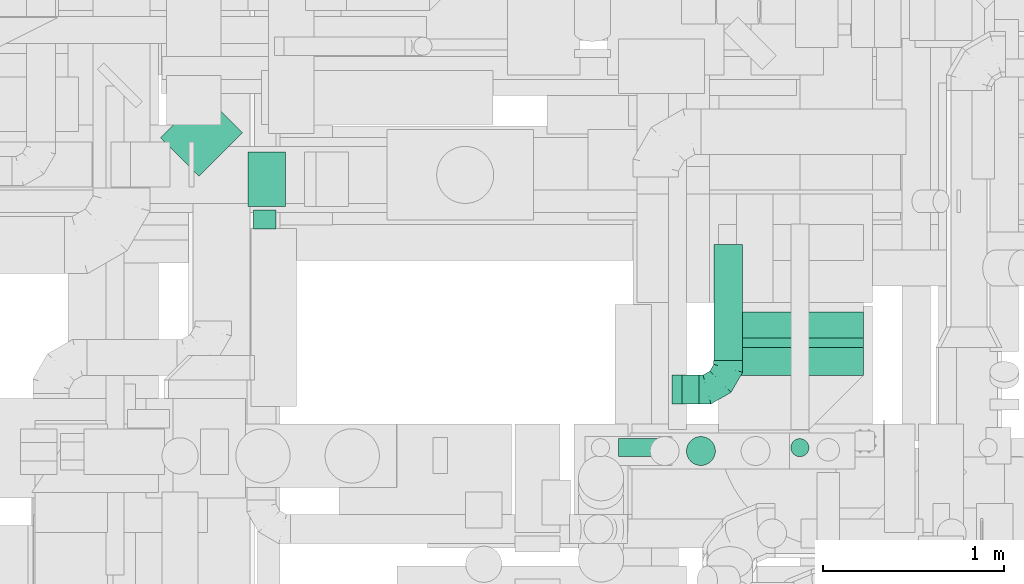
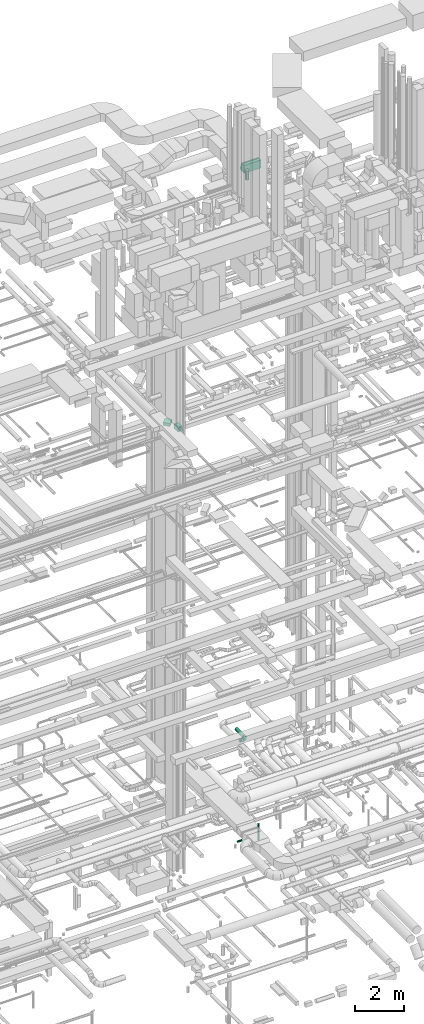
# One storey, part 190 of 337: 9 flow segments, 3 flow fittings.
"""IFC2X3 building model written with IfcOpenShell, lengths in millimetres."""

from ifc_helpers import new_model, entity, si_unit, converted_unit, derived_unit, direction, frame, frame_2d, origin, origin_2d_with_axis, place, context, subcontext, project, spatial, polyline, circle_curve, parameter, trimmed, segment, composite_curve, rectangle, circle, outline, extrude, faceted_brep, source, transform, mapped, material, type_object, type_shapes, element, save


model = new_model("IFC2X3")

# Units and contexts
model_context = context("Model", 3, precision=0.01, world=origin(), true_north=direction((6.12303176911189e-17, 1.0)))
body_context = subcontext(model_context, "Body", "Model", "MODEL_VIEW")
ifc_project = project(units=[si_unit("LENGTHUNIT", "METRE", prefix="MILLI"), si_unit("AREAUNIT", "SQUARE_METRE"), si_unit("VOLUMEUNIT", "CUBIC_METRE"), converted_unit("PLANEANGLEUNIT", "DEGREE", entity("IfcRatioMeasure", 0.0174532925199433), si_unit("PLANEANGLEUNIT", "RADIAN"), dimensions=[0, 0, 0, 0, 0, 0, 0]), si_unit("MASSUNIT", "GRAM", prefix="KILO"), derived_unit("MASSDENSITYUNIT", [(si_unit("MASSUNIT", "GRAM", prefix="KILO"), 1), (si_unit("LENGTHUNIT", "METRE"), -3)]), derived_unit("MOMENTOFINERTIAUNIT", [(si_unit("LENGTHUNIT", "METRE"), 4)]), si_unit("TIMEUNIT", "SECOND"), si_unit("FREQUENCYUNIT", "HERTZ"), si_unit("THERMODYNAMICTEMPERATUREUNIT", "DEGREE_CELSIUS"), derived_unit("THERMALTRANSMITTANCEUNIT", [(si_unit("MASSUNIT", "GRAM", prefix="KILO"), 1), (si_unit("THERMODYNAMICTEMPERATUREUNIT", "KELVIN"), -1), (si_unit("TIMEUNIT", "SECOND"), -3)]), derived_unit("VOLUMETRICFLOWRATEUNIT", [(si_unit("LENGTHUNIT", "METRE"), 3), (si_unit("TIMEUNIT", "SECOND"), -1)]), derived_unit("MASSFLOWRATEUNIT", [(si_unit("MASSUNIT", "GRAM", prefix="KILO"), 1), (si_unit("TIMEUNIT", "SECOND"), -1)]), derived_unit("ROTATIONALFREQUENCYUNIT", [(si_unit("TIMEUNIT", "SECOND"), -1)]), si_unit("ELECTRICCURRENTUNIT", "AMPERE"), si_unit("ELECTRICVOLTAGEUNIT", "VOLT"), si_unit("POWERUNIT", "WATT"), si_unit("FORCEUNIT", "NEWTON", prefix="KILO"), si_unit("ILLUMINANCEUNIT", "LUX"), si_unit("LUMINOUSFLUXUNIT", "LUMEN"), si_unit("LUMINOUSINTENSITYUNIT", "CANDELA"), derived_unit("USERDEFINED", [(si_unit("MASSUNIT", "GRAM", prefix="KILO"), -1), (si_unit("LENGTHUNIT", "METRE"), -2), (si_unit("TIMEUNIT", "SECOND"), 3), (si_unit("LUMINOUSFLUXUNIT", "LUMEN"), 1)]), derived_unit("LINEARVELOCITYUNIT", [(si_unit("LENGTHUNIT", "METRE"), 1), (si_unit("TIMEUNIT", "SECOND"), -1)]), si_unit("PRESSUREUNIT", "PASCAL"), derived_unit("USERDEFINED", [(si_unit("LENGTHUNIT", "METRE"), -2), (si_unit("MASSUNIT", "GRAM", prefix="KILO"), 1), (si_unit("TIMEUNIT", "SECOND"), -2)]), derived_unit("LINEARFORCEUNIT", [(si_unit("MASSUNIT", "GRAM", prefix="KILO"), 1), (si_unit("LENGTHUNIT", "METRE"), 1), (si_unit("TIMEUNIT", "SECOND"), -2), (si_unit("LENGTHUNIT", "METRE"), -1)]), derived_unit("PLANARFORCEUNIT", [(si_unit("MASSUNIT", "GRAM", prefix="KILO"), 1), (si_unit("LENGTHUNIT", "METRE"), 1), (si_unit("TIMEUNIT", "SECOND"), -2), (si_unit("LENGTHUNIT", "METRE"), -2)])], contexts=[model_context])

# Site, building, storey
site_placement = place(None, origin())
site = spatial("IfcSite", under=ifc_project, at=site_placement, CompositionType="ELEMENT")
building_placement = place(site_placement, origin())
building = spatial("IfcBuilding", under=site, at=building_placement, CompositionType="ELEMENT")
storey_placement = place(building_placement, origin())
storey = spatial("IfcBuildingStorey", under=building, at=storey_placement, CompositionType="ELEMENT", Elevation=0.0)

# Flow segments
duct_segment_type_1 = type_object("IfcDuctSegmentType", PredefinedType="NOTDEFINED")
flow_segment_1_placement = place(storey_placement, frame((47069.03, 14375.32, 18625.0)))
element("IfcFlowSegment", 1, at=flow_segment_1_placement, inside=storey, type_object=duct_segment_type_1, context=body_context, shape_type="SweptSolid", body=[
    extrude(rectangle(XDim=206.811291324867, YDim=300.000000000001, at=origin_2d_with_axis()), frame((103.41, 150.0, 0.0)), (0.0, 0.0, 1.0), 249.999999999999),
])
flow_segment_2_placement = place(storey_placement, frame((46586.86, 14542.35, 18900.0)))
element("IfcFlowSegment", 2, at=flow_segment_2_placement, inside=storey, type_object=duct_segment_type_1, context=body_context, shape_type="SweptSolid", body=[
    extrude(rectangle(XDim=338.334777586305, YDim=299.999999999998, at=origin_2d_with_axis()), frame((225.69, 225.69, 0.0), z_axis=(0.0, 0.0, 1.0), x_axis=(-0.707106781186519, -0.707106781186576, 0.0)), (0.0, 0.0, 1.0), 150.000000000001),
])
flow_segment_3_placement = place(storey_placement, frame((49665.39, 13441.6, 31220.0)))
element("IfcFlowSegment", 3, at=flow_segment_3_placement, inside=storey, type_object=duct_segment_type_1, context=body_context, shape_type="SweptSolid", body=[
    extrude(rectangle(XDim=154.425279360455, YDim=800.0, at=origin_2d_with_axis()), frame((400.0, 77.21, 0.0), z_axis=(0.0, 0.0, 1.0), x_axis=(0.0, 1.0, 0.0)), (0.0, 0.0, 1.0), 399.999999999996),
])
duct_segment_type_2 = type_object("IfcDuctSegmentType", PredefinedType="NOTDEFINED")
flow_segment_4_placement = place(storey_placement, frame((47098.29, 14251.04, 18715.9)))
element("IfcFlowSegment", 4, at=flow_segment_4_placement, inside=storey, type_object=duct_segment_type_2, context=body_context, shape_type="SweptSolid", body=[
    extrude(circle(Radius=62.5, at=origin_2d_with_axis()), frame((64.1, 0.0, 64.1), z_axis=(0.0, 1.0, 0.0), x_axis=(1.0, 0.0, 0.0)), (0.0, 0.0, 1.0), 104.28135458318),
])
flow_segment_5_placement = place(storey_placement, frame((49487.03, 12943.39, 31219.32)))
element("IfcFlowSegment", 5, at=flow_segment_5_placement, inside=storey, type_object=duct_segment_type_2, context=body_context, shape_type="SweptSolid", body=[
    extrude(circle(Radius=80.0, at=origin_2d_with_axis()), frame((81.6, 81.6, 0.0), z_axis=(0.0, 0.0, 1.0), x_axis=(0.0, 1.0, 0.0)), (0.0, 0.0, 1.0), 470.677726040477),
])
flow_segment_6_placement = place(storey_placement, frame((49464.33, 13282.54, 2918.4)))
element("IfcFlowSegment", 6, at=flow_segment_6_placement, inside=storey, type_object=duct_segment_type_2, context=body_context, shape_type="SweptSolid", body=[
    extrude(circle(Radius=80.0, at=origin_2d_with_axis()), frame((0.0, 81.6, 81.6), z_axis=(1.0, 0.0, 0.0), x_axis=(0.0, 1.0, 0.0)), (0.0, 0.0, 1.0), 95.0000923476669),
])
flow_segment_7_placement = place(storey_placement, frame((49637.74, 13524.14, 2918.4)))
element("IfcFlowSegment", 7, at=flow_segment_7_placement, inside=storey, type_object=duct_segment_type_2, context=body_context, shape_type="SweptSolid", body=[
    extrude(circle(Radius=80.0, at=origin_2d_with_axis()), frame((81.6, 0.0, 81.6), z_axis=(0.0, 1.0, 0.0), x_axis=(1.0, 0.0, 0.0)), (0.0, 0.0, 1.0), 639.999999999969),
])
flow_segment_8_placement = place(storey_placement, frame((49114.01, 12991.81, -1801.6)))
element("IfcFlowSegment", 8, at=flow_segment_8_placement, inside=storey, type_object=duct_segment_type_2, context=body_context, shape_type="SweptSolid", body=[
    extrude(circle(Radius=50.0, at=origin_2d_with_axis()), frame((0.0, 51.6, 51.6), z_axis=(1.0, 0.0, 0.0), x_axis=(0.0, 1.0, 0.0)), (0.0, 0.0, 1.0), 225.08837662957),
])
flow_segment_9_placement = place(storey_placement, frame((50063.03, 12991.8, -2000.0)))
element("IfcFlowSegment", 9, at=flow_segment_9_placement, inside=storey, type_object=duct_segment_type_2, context=body_context, shape_type="SweptSolid", body=[
    extrude(circle(Radius=50.0, at=origin_2d_with_axis()), frame((51.6, 51.6, 0.0), z_axis=(0.0, 0.0, 1.0), x_axis=(0.0, 1.0, 0.0)), (0.0, 0.0, 1.0), 799.999975000006),
])

# Flow fittings
ifc_material = material()
duct_fitting_type_1 = type_object("IfcDuctFittingType", PredefinedType="NOTDEFINED", material=ifc_material)
shared_shape_1 = source(origin(), body_context, "Body", "Brep", [
    faceted_brep([(-160.0, 0.0, -80.0), (-160.0, -20.71, -77.27), (-160.0, -40.0, -69.28), (-160.0, -56.57, -56.57), (-160.0, -69.28, -40.0), (-160.0, -77.27, -20.71), (-160.0, -80.0, 0.0), (-160.0, -77.27, 20.71), (-160.0, -69.28, 40.0), (-160.0, -56.57, 56.57), (-160.0, -40.0, 69.28), (-160.0, -20.71, 77.27), (-160.0, 0.0, 80.0), (-160.0, 20.71, 77.27), (-160.0, 40.0, 69.28), (-160.0, 56.57, 56.57), (-160.0, 69.28, 40.0), (-160.0, 77.27, 20.71), (-160.0, 80.0, 0.0), (-160.0, 77.27, -20.71), (-160.0, 69.28, -40.0), (-160.0, 56.57, -56.57), (-160.0, 40.0, -69.28), (-160.0, 20.71, -77.27), (-122.68, 20.71, 77.27), (-127.85, 40.0, 69.28), (-117.13, 0.0, 80.0), (-132.29, 56.57, 56.57), (-137.83, 77.27, 20.71), (-138.56, 80.0, 0.0), (-135.69, 69.28, 40.0), (-135.69, 69.28, -40.0), (-132.29, 56.57, -56.57), (-137.83, 77.27, -20.71), (-122.68, 20.71, -77.27), (-117.13, 0.0, -80.0), (-127.85, 40.0, -69.28), (-111.58, -20.71, -77.27), (-106.41, -40.0, -69.28), (-101.97, -56.57, -56.57), (-98.56, -69.28, -40.0), (-96.42, -77.27, -20.71), (-95.69, -80.0, 0.0), (-96.42, -77.27, 20.71), (-98.56, -69.28, 40.0), (-101.97, -56.57, 56.57), (-106.41, -40.0, 69.28), (-111.58, -20.71, 77.27), (-58.03, 58.03, 77.27), (-72.15, 72.15, 69.28), (-42.87, 42.87, 80.0), (-84.28, 84.28, 56.57), (-93.59, 93.59, 40.0), (-99.44, 99.44, 20.71), (-101.44, 101.44, 0.0), (-99.44, 99.44, -20.71), (-93.59, 93.59, -40.0), (-84.28, 84.28, -56.57), (-58.03, 58.03, -77.27), (-42.87, 42.87, -80.0), (-72.15, 72.15, -69.28), (-27.71, 27.71, -77.27), (-13.59, 13.59, -69.28), (-1.46, 1.46, -56.57), (7.85, -7.85, -40.0), (13.7, -13.7, -20.71), (15.69, -15.69, 0.0), (13.7, -13.7, 20.71), (7.85, -7.85, 40.0), (-1.46, 1.46, 56.57), (-13.59, 13.59, 69.28), (-27.71, 27.71, 77.27), (-20.71, 122.68, 77.27), (-40.0, 127.85, 69.28), (0.0, 117.13, 80.0), (-56.57, 132.29, 56.57), (-69.28, 135.69, 40.0), (-77.27, 137.83, 20.71), (-80.0, 138.56, 0.0), (-77.27, 137.83, -20.71), (-69.28, 135.69, -40.0), (-56.57, 132.29, -56.57), (-20.71, 122.68, -77.27), (0.0, 117.13, -80.0), (-40.0, 127.85, -69.28), (20.71, 111.58, -77.27), (40.0, 106.41, -69.28), (56.57, 101.97, -56.57), (69.28, 98.56, -40.0), (77.27, 96.42, -20.71), (80.0, 95.69, 0.0), (77.27, 96.42, 20.71), (69.28, 98.56, 40.0), (56.57, 101.97, 56.57), (40.0, 106.41, 69.28), (20.71, 111.58, 77.27), (-20.71, 160.0, -77.27), (-40.0, 160.0, -69.28), (-56.57, 160.0, -56.57), (-69.28, 160.0, -40.0), (-77.27, 160.0, -20.71), (-80.0, 160.0, 0.0), (-77.27, 160.0, 20.71), (-69.28, 160.0, 40.0), (-56.57, 160.0, 56.57), (-40.0, 160.0, 69.28), (-20.71, 160.0, 77.27), (0.0, 160.0, 80.0), (20.71, 160.0, 77.27), (40.0, 160.0, 69.28), (56.57, 160.0, 56.57), (69.28, 160.0, 40.0), (77.27, 160.0, 20.71), (80.0, 160.0, 0.0), (77.27, 160.0, -20.71), (69.28, 160.0, -40.0), (56.57, 160.0, -56.57), (40.0, 160.0, -69.28), (20.71, 160.0, -77.27), (0.0, 160.0, -80.0)], [[[0, 1, 2, 3, 4, 5, 6, 7, 8, 9, 10, 11, 12, 13, 14, 15, 16, 17, 18, 19, 20, 21, 22, 23]], [[24, 25, 14, 13]], [[26, 24, 13, 12]], [[14, 25, 27, 15]], [[28, 29, 18, 17]], [[30, 28, 17, 16]], [[15, 27, 30, 16]], [[20, 31, 32, 21]], [[33, 31, 20, 19]], [[18, 29, 33, 19]], [[34, 35, 0, 23]], [[36, 34, 23, 22]], [[32, 36, 22, 21]], [[1, 0, 35, 37]], [[2, 1, 37, 38]], [[3, 2, 38, 39]], [[5, 4, 40, 41]], [[6, 5, 41, 42]], [[39, 40, 4, 3]], [[6, 42, 43, 7]], [[7, 43, 44, 8]], [[8, 44, 45, 9]], [[9, 45, 46, 10]], [[10, 46, 47, 11]], [[26, 12, 11, 47]], [[48, 49, 25, 24]], [[50, 48, 24, 26]], [[27, 25, 49, 51]], [[52, 53, 28, 30]], [[51, 52, 30, 27]], [[29, 28, 53, 54]], [[55, 56, 31, 33]], [[54, 55, 33, 29]], [[32, 31, 56, 57]], [[58, 59, 35, 34]], [[60, 58, 34, 36]], [[57, 60, 36, 32]], [[37, 35, 59, 61]], [[38, 37, 61, 62]], [[39, 38, 62, 63]], [[41, 40, 64, 65]], [[42, 41, 65, 66]], [[63, 64, 40, 39]], [[43, 42, 66, 67]], [[44, 43, 67, 68]], [[68, 69, 45, 44]], [[46, 45, 69, 70]], [[47, 46, 70, 71]], [[26, 47, 71, 50]], [[72, 73, 49, 48]], [[74, 72, 48, 50]], [[51, 49, 73, 75]], [[76, 77, 53, 52]], [[75, 76, 52, 51]], [[54, 53, 77, 78]], [[79, 80, 56, 55]], [[78, 79, 55, 54]], [[57, 56, 80, 81]], [[82, 83, 59, 58]], [[84, 82, 58, 60]], [[81, 84, 60, 57]], [[61, 59, 83, 85]], [[62, 61, 85, 86]], [[63, 62, 86, 87]], [[65, 64, 88, 89]], [[66, 65, 89, 90]], [[87, 88, 64, 63]], [[67, 66, 90, 91]], [[68, 67, 91, 92]], [[92, 93, 69, 68]], [[70, 69, 93, 94]], [[71, 70, 94, 95]], [[50, 71, 95, 74]], [[96, 97, 98, 99, 100, 101, 102, 103, 104, 105, 106, 107, 108, 109, 110, 111, 112, 113, 114, 115, 116, 117, 118, 119]], [[72, 74, 107, 106]], [[73, 72, 106, 105]], [[75, 73, 105, 104]], [[77, 76, 103, 102]], [[78, 77, 102, 101]], [[75, 104, 103, 76]], [[78, 101, 100, 79]], [[79, 100, 99, 80]], [[80, 99, 98, 81]], [[84, 97, 96, 82]], [[82, 96, 119, 83]], [[84, 81, 98, 97]], [[118, 117, 86, 85]], [[119, 118, 85, 83]], [[116, 87, 86, 117]], [[88, 115, 114, 89]], [[89, 114, 113, 90]], [[115, 88, 87, 116]], [[112, 111, 92, 91]], [[113, 112, 91, 90]], [[111, 110, 93, 92]], [[95, 94, 109, 108]], [[74, 95, 108, 107]], [[110, 109, 94, 93]]]),
])
type_shapes(duct_fitting_type_1, [shared_shape_1])
flow_fitting_1_placement = place(storey_placement, frame((49719.33, 13364.14, 3000.0)))
element("IfcFlowFitting", 10, at=flow_fitting_1_placement, inside=storey, type_object=duct_fitting_type_1, material=ifc_material, context=body_context, shape_type="MappedRepresentation", body=[
    mapped(shared_shape_1, transform((0.0, 0.0, 0.0), scale=1.0)),
])
duct_fitting_type_2 = type_object("IfcDuctFittingType", PredefinedType="NOTDEFINED", material=ifc_material)
shared_shape_2 = source(origin(), body_context, "Body", "Brep", [
    faceted_brep([(20.0, 20.71, -77.27), (20.0, 40.0, -69.28), (20.0, 56.57, -56.57), (20.0, 69.28, -40.0), (20.0, 77.27, -20.71), (20.0, 80.0, 0.0), (20.0, 77.27, 20.71), (20.0, 69.28, 40.0), (20.0, 56.57, 56.57), (20.0, 40.0, 69.28), (20.0, 20.71, 77.27), (20.0, 0.0, 80.0), (20.0, -20.71, 77.27), (20.0, -40.0, 69.28), (20.0, -56.57, 56.57), (20.0, -69.28, 40.0), (20.0, -77.27, 20.71), (20.0, -80.0, 0.0), (20.0, -77.27, -20.71), (20.0, -69.28, -40.0), (20.0, -56.57, -56.57), (20.0, -40.0, -69.28), (20.0, -20.71, -77.27), (20.0, 0.0, -80.0), (0.0, 0.0, 80.0), (0.0, 20.71, 77.27), (-35.05, 20.71, 77.27), (-35.05, 0.0, 80.0), (0.0, 40.0, 69.28), (-35.05, 40.0, 69.28), (0.0, 56.57, 56.57), (-35.05, 56.57, 56.57), (0.0, 69.28, 40.0), (0.0, 77.27, 20.71), (-35.05, 77.27, 20.71), (-35.05, 69.28, 40.0), (0.0, 80.0, 0.0), (-35.05, 80.0, 0.0), (0.0, 77.27, -20.71), (-35.05, 77.27, -20.71), (0.0, 69.28, -40.0), (-35.05, 69.28, -40.0), (0.0, 56.57, -56.57), (-35.05, 56.57, -56.57), (0.0, 40.0, -69.28), (0.0, 20.71, -77.27), (-35.05, 20.71, -77.27), (-35.05, 40.0, -69.28), (0.0, 0.0, -80.0), (-35.05, 0.0, -80.0), (0.0, -20.71, -77.27), (-35.05, -20.71, -77.27), (0.0, -40.0, -69.28), (-35.05, -40.0, -69.28), (0.0, -56.57, -56.57), (-35.05, -56.57, -56.57), (0.0, -69.28, -40.0), (0.0, -77.27, -20.71), (-35.05, -77.27, -20.71), (-35.05, -69.28, -40.0), (0.0, -80.0, 0.0), (-35.05, -80.0, 0.0), (0.0, -77.27, 20.71), (-35.05, -77.27, 20.71), (0.0, -69.28, 40.0), (-35.05, -69.28, 40.0), (0.0, -56.57, 56.57), (-35.05, -56.57, 56.57), (0.0, -40.0, 69.28), (0.0, -20.71, 77.27), (-35.05, -20.71, 77.27), (-35.05, -40.0, 69.28)], [[[0, 1, 2, 3, 4, 5, 6, 7, 8, 9, 10, 11, 12, 13, 14, 15, 16, 17, 18, 19, 20, 21, 22, 23]], [[24, 11, 10, 25, 26, 27]], [[25, 10, 9, 28, 29, 26]], [[28, 9, 8, 30, 31, 29]], [[32, 7, 6, 33, 34, 35]], [[33, 6, 5, 36, 37, 34]], [[30, 8, 7, 32, 35, 31]], [[36, 5, 4, 38, 39, 37]], [[38, 4, 3, 40, 41, 39]], [[40, 3, 2, 42, 43, 41]], [[44, 1, 0, 45, 46, 47]], [[45, 0, 23, 48, 49, 46]], [[42, 2, 1, 44, 47, 43]], [[48, 23, 22, 50, 51, 49]], [[50, 22, 21, 52, 53, 51]], [[52, 21, 20, 54, 55, 53]], [[56, 19, 18, 57, 58, 59]], [[57, 18, 17, 60, 61, 58]], [[54, 20, 19, 56, 59, 55]], [[60, 17, 16, 62, 63, 61]], [[62, 16, 15, 64, 65, 63]], [[64, 15, 14, 66, 67, 65]], [[68, 13, 12, 69, 70, 71]], [[69, 12, 11, 24, 27, 70]], [[66, 14, 13, 68, 71, 67]], [[49, 51, 53, 55, 59, 58, 61, 63, 65, 67, 71, 70, 27, 26, 29, 31, 35, 34, 37, 39, 41, 43, 47, 46]]]),
])
type_shapes(duct_fitting_type_2, [shared_shape_2])
flow_fitting_2_placement = place(storey_placement, frame((49444.33, 13364.14, 3000.0), z_axis=(0.0, 0.0, -1.0), x_axis=(1.0, 0.0, 0.0)))
element("IfcFlowFitting", 11, at=flow_fitting_2_placement, inside=storey, type_object=duct_fitting_type_2, material=ifc_material, context=body_context, shape_type="MappedRepresentation", body=[
    mapped(shared_shape_2, transform((0.0, 0.0, 0.0), scale=1.0)),
])
duct_fitting_type_3 = type_object("IfcDuctFittingType", PredefinedType="NOTDEFINED", material=ifc_material)
shared_shape_3 = source(origin(), body_context, "Body", "SweptSolid", [
    extrude(outline(composite_curve([segment(polyline([(-211.61, -62.67), (188.39, -62.67)]), True, "CONTINUOUS"), segment(trimmed(circle_curve(frame_2d((338.39, -62.67), x_axis=(-0.933679897750565, 0.358108710500728)), 150.0), [parameter(0.0)], [parameter(20.9840908063534)], True, "PARAMETER"), False, "CONTINUOUS"), segment(polyline([(198.34, -8.95), (-175.13, 134.29)]), True, "CONTINUOUS"), segment(trimmed(circle_curve(frame_2d((338.39, -62.67), x_axis=(-0.933679897750565, 0.358108710500728)), 550.0), [parameter(0.0)], [parameter(20.9840908063534)], True, "PARAMETER"), True, "CONTINUOUS")], self_intersect=False)), frame((-2.15, 11.61, -400.0), z_axis=(0.0, 0.0, 1.0), x_axis=(-0.358108710500728, 0.933679897750565, 0.0)), (0.0, 0.0, 1.0), 800.0),
])
type_shapes(duct_fitting_type_3, [shared_shape_3])
flow_fitting_3_placement = place(storey_placement, frame((50065.39, 13660.85, 31420.0), z_axis=(-1.0, 0.0, 0.0), x_axis=(0.0, -0.933679897750553, -0.358108710500759)))
element("IfcFlowFitting", 12, at=flow_fitting_3_placement, inside=storey, type_object=duct_fitting_type_3, material=ifc_material, context=body_context, shape_type="MappedRepresentation", body=[
    mapped(shared_shape_3, transform((0.0, 0.0, 0.0), scale=1.0)),
])

save(model, "model.ifc")
